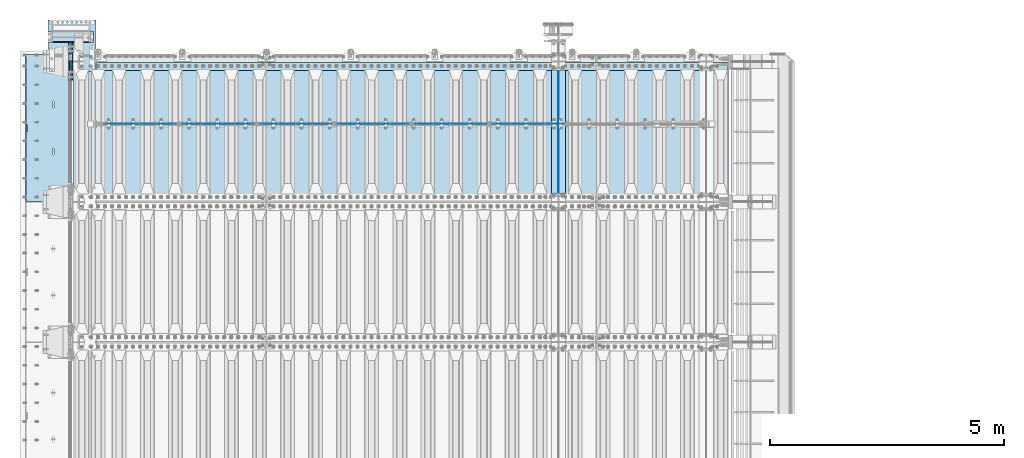
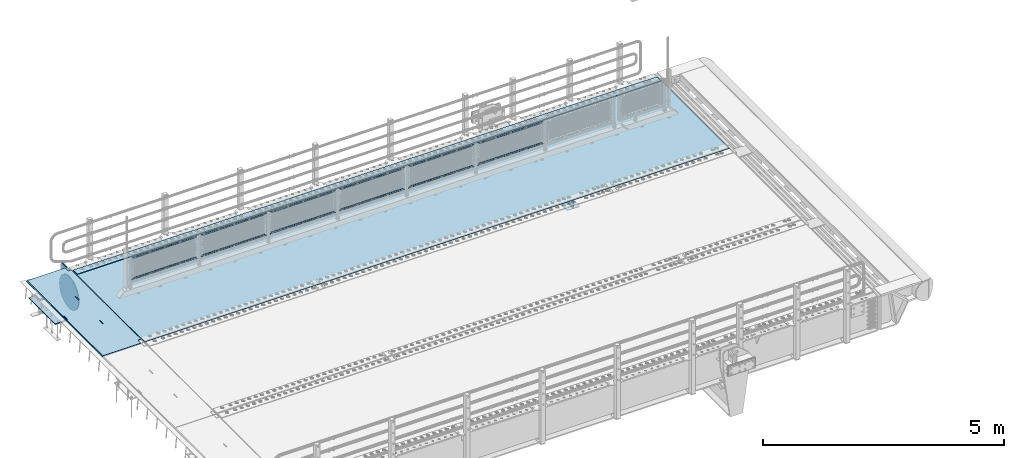
# One storey, part 172 of 219: 21 plates.
"""IFC2X3 building model written with IfcOpenShell, lengths in millimetres."""

from ifc_helpers import new_model, si_unit, frame, origin_with_axes, place, context, subcontext, project, spatial, faceted_brep, material, type_object, element, save


model = new_model("IFC2X3")

# Units and contexts
model_context = context("Model", 3, precision=1e-05, world=origin_with_axes())
body_context = subcontext(model_context, "Body", "Model", "MODEL_VIEW")
ifc_project = project(units=[si_unit("LENGTHUNIT", "METRE", prefix="MILLI"), si_unit("AREAUNIT", "SQUARE_METRE"), si_unit("VOLUMEUNIT", "CUBIC_METRE"), si_unit("MASSUNIT", "GRAM", prefix="KILO"), si_unit("TIMEUNIT", "SECOND"), si_unit("PLANEANGLEUNIT", "RADIAN"), si_unit("SOLIDANGLEUNIT", "STERADIAN"), si_unit("THERMODYNAMICTEMPERATUREUNIT", "DEGREE_CELSIUS"), si_unit("LUMINOUSINTENSITYUNIT", "LUMEN")], contexts=[model_context])

# Site, building, storey
site_placement = place(None, origin_with_axes())
site = spatial("IfcSite", under=ifc_project, at=site_placement, CompositionType="ELEMENT")
building_placement = place(site_placement, origin_with_axes())
building = spatial("IfcBuilding", under=site, at=building_placement, Name="Standard", CompositionType="ELEMENT")
storey_placement = place(building_placement, origin_with_axes())
storey = spatial("IfcBuildingStorey", under=building, at=storey_placement, Name="Undefined", CompositionType="ELEMENT", Elevation=0.0)

# Plates
ifc_material_1 = material(Name="STEEL/S355N")
plate_type_1 = type_object("IfcPlateType", PredefinedType="NOTDEFINED")
plate_1_placement = place(storey_placement, frame((-5.0037545708802, 33149.9999261293, -0.984391683369127), z_axis=(0.0, -0.999999999987744, -4.95099999993769e-06), x_axis=(-0.999999999879068, -1.00000022172504e-09, -1.55519999981193e-05)))
element("IfcPlate", 1, at=plate_1_placement, inside=storey, type_object=plate_type_1, material=ifc_material_1, context=body_context, shape_type="Brep", body=[
    faceted_brep([(14.9998601691701, 15.0, 125.000024820867), (-0.000294611402126499, -0.000806902977099622, 124.999936248674), (-0.0019194158154896, 0.000806844435372156, 3020.00000492308), (14.9966216875132, 15.0, 3020.00007976656), (999.996459960937, 4.99999999999999, 3.63797880709171e-12), (984.996459960937, 15.0, 3.63797880709171e-12), (984.996459718778, 15.0, 3145.0), (999.996459718778, 4.99999999999999, 3145.0), (984.996459961366, -15.0, 0.0), (999.996459960937, -5.0, 3.63797880709171e-12), (999.996459718778, -5.0, 3145.0), (984.996459719206, -15.0, 3145.0), (74.999782061445, -15.0, 0.0), (74.9996421865538, -15.0000000127077, 124.999930084141), (75.0001087165527, 15.0, 125.00007975414), (75.0002485914438, 15.0, 0.0), (-0.000449375328763324, -14.9999999951864, 124.999861417786), (395.486056604107, -15.0000000067239, 2004.409830054), (395.486056604107, 15.0, 2004.409830054), (394.996621766821, 15.0, 2007.49999999776), (394.996621766821, -15.0000000067363, 2007.49999999776), (396.906451823524, -15.0000000066914, 2001.62214747483), (396.906451823524, 15.0, 2001.62214747483), (399.11876924452, -15.0000000066418, 1999.409830054), (399.11876924452, 15.0, 1999.409830054), (401.906451823804, -15.0000000065801, 1997.98943483481), (401.906451823804, 15.0, 1997.9894348348), (404.996621767592, -15.0000000065123, 1997.49999999776), (404.996621767592, 15.0, 1997.49999999775), (408.086791711187, -15.0000000064451, 1997.9894348348), (408.086791711187, 15.0, 1997.9894348348), (410.874474290252, -15.0000000063849, 1999.409830054), (410.874474290252, 15.0, 1999.409830054), (413.086791710906, -15.0000000063378, 2001.62214747483), (413.086791710906, 15.0, 2001.62214747482), (414.507186929894, -15.0000000063082, 2004.409830054), (414.507186929894, 15.0, 2004.409830054), (414.996621766706, -15.0000000062992, 2007.49999999775), (414.996621766706, 15.0, 2007.49999999774), (414.996621756792, -15.0000000063698, 2137.49999999775), (414.996621756792, 15.0, 2137.49999999774), (414.507186919508, -15.0000000063821, 2140.5901699415), (414.507186919508, 15.0, 2140.5901699415), (413.086791700092, -15.0000000064147, 2143.37785252068), (413.086791700092, 15.0, 2143.37785252067), (410.874474279096, -15.0000000064642, 2145.5901699415), (410.874474279096, 15.0, 2145.5901699415), (408.08679169981, -15.0000000065259, 2147.01056516071), (408.08679169981, 15.0, 2147.01056516071), (404.996621756022, -15.0000000065937, 2147.49999999775), (404.996621756022, 15.0, 2147.49999999775), (401.906451812318, -15.000000006661, 2147.01056516071), (401.906451812318, 15.0, 2147.0105651607), (399.118769233252, -15.0000000067211, 2145.5901699415), (399.118769233252, 15.0, 2145.5901699415), (396.906451812598, -15.0000000067683, 2143.37785252068), (396.906451812598, 15.0, 2143.37785252068), (395.486056593611, -15.0000000067978, 2140.5901699415), (395.486056593611, 15.0, 2140.5901699415), (394.996621756801, -15.0000000068068, 2137.49999999776), (394.996621756801, 15.0, 2137.49999999776), (960.486056642603, -14.9999999941054, 1504.40983005424), (960.486056642603, 15.0, 1504.40983005424), (959.996621805317, 15.0, 1507.49999999799), (959.996621805317, -14.9999999941178, 1507.49999999799), (961.90645186202, -14.9999999940729, 1501.62214747507), (961.906451862021, 15.0, 1501.62214747506), (964.118769283016, -14.9999999940233, 1499.40983005424), (964.118769283016, 15.0, 1499.40983005424), (966.9064518623, -14.9999999939616, 1497.98943483504), (966.906451862301, 15.0, 1497.98943483504), (969.996621806087, -14.9999999938938, 1497.49999999799), (969.996621806088, 15.0, 1497.49999999799), (973.086791749683, -14.9999999938266, 1497.98943483504), (973.086791749683, 15.0, 1497.98943483504), (975.874474328748, -14.9999999937664, 1499.40983005424), (975.874474328748, 15.0, 1499.40983005424), (978.086791749402, -14.9999999937193, 1501.62214747506), (978.086791749402, 15.0, 1501.62214747506), (979.50718696839, -14.9999999936897, 1504.40983005424), (979.50718696839, 15.0, 1504.40983005424), (979.996621805202, -14.9999999936807, 1507.49999999798), (979.996621805202, 15.0, 1507.49999999798), (979.996621795288, -14.9999999937513, 1637.49999999798), (979.996621795288, 15.0, 1637.49999999798), (979.507186958004, -14.9999999937636, 1640.59016994173), (979.507186958004, 15.0, 1640.59016994173), (978.086791738588, -14.9999999937962, 1643.37785252092), (978.086791738588, 15.0, 1643.37785252092), (975.874474317592, -14.9999999938457, 1645.59016994174), (975.874474317592, 15.0, 1645.59016994174), (973.086791738306, -14.9999999939074, 1647.01056516094), (973.086791738306, 15.0, 1647.01056516094), (969.996621794518, -14.9999999939752, 1647.499999998), (969.996621794518, 15.0, 1647.49999999799), (966.906451850814, -14.9999999940425, 1647.01056516094), (966.906451850814, 15.0, 1647.01056516094), (964.118769271748, -14.9999999941026, 1645.59016994174), (964.118769271748, 15.0, 1645.59016994174), (961.906451851094, -14.9999999941498, 1643.37785252092), (961.906451851094, 15.0, 1643.37785252092), (960.486056632107, -14.9999999941793, 1640.59016994174), (960.486056632107, 15.0, 1640.59016994174), (959.996621795297, -14.9999999941883, 1637.49999999799), (959.996621795297, 15.0, 1637.49999999799), (74.9967306508983, 15.0, 3145.0), (74.9962640908995, -15.0, 3145.0), (74.9968705257886, 15.0, 3020.00007982416), (74.9964039657899, -15.0, 3019.99993015416), (-0.000460362174934836, -15.00000004538, 3019.99993008595), (395.486056670595, -15.0000000062551, 1140.59016994198), (396.906451889582, -15.0000000062256, 1143.37785252116), (399.118769310236, -15.0000000061784, 1145.59016994198), (401.906451889302, -15.0000000061183, 1147.01056516119), (404.996621833006, -15.000000006051, 1147.49999999823), (408.086791776794, -15.0000000059832, 1147.01056516119), (410.87447435608, -15.0000000059215, 1145.59016994198), (413.086791777076, -15.000000005872, 1143.37785252116), (414.507186996492, -15.0000000058395, 1140.59016994198), (414.996621833776, -15.0000000058271, 1137.49999999823), (414.99662184369, -15.0000000057565, 1007.49999999823), (414.507187006878, -15.0000000057655, 1004.40983005448), (413.08679178789, -15.0000000057951, 1001.62214747531), (410.874474367236, -15.0000000058422, 999.409830054483), (408.086791788171, -15.0000000059024, 997.989434835283), (404.996621844575, -15.0000000059696, 997.499999998232), (401.906451900788, -15.0000000060374, 997.989434835286), (399.118769321504, -15.0000000060991, 999.409830054483), (396.906451900508, -15.0000000061487, 1001.62214747531), (395.486056681091, -15.0000000061812, 1004.40983005449), (394.996621843805, -15.0000000061936, 1007.49999999824), (394.996621833785, -15.0000000062641, 1137.49999999824), (396.906451900508, 15.0, 1001.62214747531), (395.486056681091, 15.0, 1004.40983005448), (399.118769321504, 15.0, 999.409830054483), (401.906451900788, 15.0, 997.989434835283), (404.996621844575, 15.0, 997.499999998228), (408.086791788171, 15.0, 997.989434835283), (410.874474367236, 15.0, 999.409830054483), (413.08679178789, 15.0, 1001.6221474753), (414.507187006878, 15.0, 1004.40983005448), (414.99662184369, 15.0, 1007.49999999822), (414.996621833776, 15.0, 1137.49999999822), (414.507186996492, 15.0, 1140.59016994198), (413.086791777076, 15.0, 1143.37785252115), (410.87447435608, 15.0, 1145.59016994198), (408.086791776794, 15.0, 1147.01056516119), (404.996621833006, 15.0, 1147.49999999823), (401.906451889302, 15.0, 1147.01056516118), (399.118769310236, 15.0, 1145.59016994198), (396.906451889582, 15.0, 1143.37785252116), (395.486056670595, 15.0, 1140.59016994198), (394.996621833785, 15.0, 1137.49999999824), (394.996621843805, 15.0, 1007.49999999824)], [[[0, 1, 2, 3]], [[4, 5, 6, 7]], [[8, 9, 10, 11]], [[12, 13, 14, 15]], [[14, 13, 16, 1, 0]], [[17, 18, 19, 20]], [[21, 22, 18, 17]], [[23, 24, 22, 21]], [[25, 26, 24, 23]], [[27, 28, 26, 25]], [[29, 30, 28, 27]], [[31, 32, 30, 29]], [[33, 34, 32, 31]], [[35, 36, 34, 33]], [[37, 38, 36, 35]], [[39, 40, 38, 37]], [[41, 42, 40, 39]], [[43, 44, 42, 41]], [[45, 46, 44, 43]], [[47, 48, 46, 45]], [[49, 50, 48, 47]], [[51, 52, 50, 49]], [[53, 54, 52, 51]], [[55, 56, 54, 53]], [[57, 58, 56, 55]], [[59, 60, 58, 57]], [[20, 19, 60, 59]], [[61, 62, 63, 64]], [[65, 66, 62, 61]], [[67, 68, 66, 65]], [[69, 70, 68, 67]], [[71, 72, 70, 69]], [[73, 74, 72, 71]], [[75, 76, 74, 73]], [[77, 78, 76, 75]], [[79, 80, 78, 77]], [[81, 82, 80, 79]], [[83, 84, 82, 81]], [[85, 86, 84, 83]], [[87, 88, 86, 85]], [[89, 90, 88, 87]], [[91, 92, 90, 89]], [[93, 94, 92, 91]], [[95, 96, 94, 93]], [[97, 98, 96, 95]], [[99, 100, 98, 97]], [[101, 102, 100, 99]], [[103, 104, 102, 101]], [[64, 63, 104, 103]], [[9, 8, 12, 15, 5, 4]], [[10, 9, 4, 7]], [[105, 106, 11, 10, 7, 6]], [[106, 105, 107, 108]], [[109, 108, 107, 3, 2]], [[106, 108, 109, 16, 13, 12, 8, 11], [101, 99, 97, 95, 93, 91, 89, 87, 85, 83, 81, 79, 77, 75, 73, 71, 69, 67, 65, 61, 64, 103], [57, 55, 53, 51, 49, 47, 45, 43, 41, 39, 37, 35, 33, 31, 29, 27, 25, 23, 21, 17, 20, 59], [110, 111, 112, 113, 114, 115, 116, 117, 118, 119, 120, 121, 122, 123, 124, 125, 126, 127, 128, 129, 130, 131]], [[128, 132, 133, 129]], [[127, 134, 132, 128]], [[126, 135, 134, 127]], [[125, 136, 135, 126]], [[124, 137, 136, 125]], [[123, 138, 137, 124]], [[122, 139, 138, 123]], [[121, 140, 139, 122]], [[120, 141, 140, 121]], [[119, 142, 141, 120]], [[118, 143, 142, 119]], [[117, 144, 143, 118]], [[116, 145, 144, 117]], [[115, 146, 145, 116]], [[114, 147, 146, 115]], [[113, 148, 147, 114]], [[112, 149, 148, 113]], [[111, 150, 149, 112]], [[110, 151, 150, 111]], [[131, 152, 151, 110]], [[130, 153, 152, 131]], [[129, 133, 153, 130]], [[107, 105, 6, 5, 15, 14, 0, 3], [132, 134, 135, 136, 137, 138, 139, 140, 141, 142, 143, 144, 145, 146, 147, 148, 149, 150, 151, 152, 153, 133], [22, 24, 26, 28, 30, 32, 34, 36, 38, 40, 42, 44, 46, 48, 50, 52, 54, 56, 58, 60, 19, 18], [66, 68, 70, 72, 74, 76, 78, 80, 82, 84, 86, 88, 90, 92, 94, 96, 98, 100, 102, 104, 63, 62]], [[16, 109, 2, 1]]]),
])
plate_type_2 = type_object("IfcPlateType", PredefinedType="NOTDEFINED")
plate_2_placement = place(storey_placement, frame((10390.0, 32825.0, 0.0), z_axis=(0.0, 0.0, -1.0), x_axis=(0.0, -1.0, 0.0)))
element("IfcPlate", 2, at=plate_2_placement, inside=storey, type_object=plate_type_2, material=ifc_material_1, context=body_context, shape_type="Brep", body=[
    faceted_brep([(0.0, -5.0, 0.0), (0.0, -5.0, 336.0), (0.0, 5.0, 336.0), (0.0, 5.0, 0.0), (2650.0, -5.0, 336.0), (2650.0, 5.0, 336.0), (2650.0, -5.0, 0.0), (2650.0, 5.0, 0.0)], [[[0, 1, 2, 3]], [[1, 4, 5, 2]], [[4, 6, 7, 5]], [[6, 0, 3, 7]], [[5, 7, 3, 2]], [[6, 4, 1, 0]]]),
])
plate_type_3 = type_object("IfcPlateType", PredefinedType="NOTDEFINED")
plate_3_placement = place(storey_placement, frame((10240.0, 30175.0, -343.0), z_axis=(0.0, 1.0, 0.0), x_axis=(1.0, 0.0, 0.0)))
element("IfcPlate", 3, at=plate_3_placement, inside=storey, type_object=plate_type_3, material=ifc_material_1, context=body_context, shape_type="Brep", body=[
    faceted_brep([(0.0, -7.0, 0.0), (0.0, -7.0, 2650.0), (0.0, 7.0, 2650.0), (0.0, 7.0, 0.0), (300.0, -7.0, 2650.0), (300.0, 7.0, 2650.0), (300.0, -7.0, 0.0), (300.0, 7.0, 0.0)], [[[0, 1, 2, 3]], [[1, 4, 5, 2]], [[4, 6, 7, 5]], [[6, 0, 3, 7]], [[5, 7, 3, 2]], [[6, 4, 1, 0]]]),
])
ifc_material_2 = material(Name="Misc_Undefined")
plate_type_4 = type_object("IfcPlateType", PredefinedType="NOTDEFINED")
plate_4_placement = place(storey_placement, frame((8964.50501173036, 31670.5, 351.520303374641), z_axis=(0.0, 0.0, 1.0), x_axis=(1.0, 0.0, 0.0)))
element("IfcPlate", 4, at=plate_4_placement, inside=storey, type_object=plate_type_4, material=ifc_material_2, context=body_context, shape_type="Brep", body=[
    faceted_brep([(0.0, -1.5, -5.6843418860808e-14), (35.0002975463885, -1.5, 34.9996948242187), (35.0002975463885, 1.5, 34.9996948242187), (0.0, 1.5, -5.6843418860808e-14), (1515.99035644531, -1.5, 34.9999923706054), (1515.99035644531, 1.5, 34.9999923706054), (1550.98999023438, -1.5, 4.43037606601138e-09), (1550.98999023438, 1.5, 4.43037606601138e-09)], [[[0, 1, 2, 3]], [[1, 4, 5, 2]], [[4, 6, 7, 5]], [[6, 0, 3, 7]], [[5, 7, 3, 2]], [[6, 4, 1, 0]]]),
])
plate_5_placement = place(storey_placement, frame((10515.5000001876, 31670.5, 914.520000175701), z_axis=(-0.707103624179499, 0.0, 0.707109938179501), x_axis=(-0.707109938179508, 0.0, -0.707103624179492)))
element("IfcPlate", 5, at=plate_5_placement, inside=storey, type_object=plate_type_4, material=ifc_material_2, context=body_context, shape_type="Brep", body=[
    faceted_brep([(0.0, -1.5, -5.6843418860808e-14), (1096.72753906249, -1.5, 1096.7177734375), (1096.72753906249, 1.5, 1096.7177734375), (0.0, 1.5, -5.6843418860808e-14), (1096.72045898437, -1.5, 1047.21337890625), (1096.72045898437, 1.5, 1047.21337890625), (49.4976959228516, -1.5, -1.0550138540566e-10), (49.4976959228516, 1.5, -1.0550138540566e-10)], [[[0, 1, 2, 3]], [[1, 4, 5, 2]], [[4, 6, 7, 5]], [[6, 0, 3, 7]], [[5, 7, 3, 2]], [[6, 4, 1, 0]]]),
])
plate_6_placement = place(storey_placement, frame((7306.50501173036, 31670.5, 351.520303374641), z_axis=(0.0, 0.0, 1.0), x_axis=(1.0, 0.0, 0.0)))
element("IfcPlate", 6, at=plate_6_placement, inside=storey, type_object=plate_type_4, material=ifc_material_2, context=body_context, shape_type="Brep", body=[
    faceted_brep([(0.0, -1.5, -5.6843418860808e-14), (35.0002975463885, -1.5, 34.9996948242187), (35.0002975463885, 1.5, 34.9996948242187), (0.0, 1.5, -5.6843418860808e-14), (1515.99035644531, -1.5, 34.9999923706054), (1515.99035644531, 1.5, 34.9999923706054), (1550.98999023438, -1.5, 4.43037606601138e-09), (1550.98999023438, 1.5, 4.43037606601138e-09)], [[[0, 1, 2, 3]], [[1, 4, 5, 2]], [[4, 6, 7, 5]], [[6, 0, 3, 7]], [[5, 7, 3, 2]], [[6, 4, 1, 0]]]),
])
plate_7_placement = place(storey_placement, frame((8857.5000001876, 31670.5, 914.520000175701), z_axis=(-0.707103624179499, 0.0, 0.707109938179501), x_axis=(-0.707109938179508, 0.0, -0.707103624179492)))
element("IfcPlate", 7, at=plate_7_placement, inside=storey, type_object=plate_type_4, material=ifc_material_2, context=body_context, shape_type="Brep", body=[
    faceted_brep([(0.0, -1.5, -5.6843418860808e-14), (1096.72753906249, -1.5, 1096.7177734375), (1096.72753906249, 1.5, 1096.7177734375), (0.0, 1.5, -5.6843418860808e-14), (1096.72045898437, -1.5, 1047.21337890625), (1096.72045898437, 1.5, 1047.21337890625), (49.4976959228516, -1.5, -1.0550138540566e-10), (49.4976959228516, 1.5, -1.0550138540566e-10)], [[[0, 1, 2, 3]], [[1, 4, 5, 2]], [[4, 6, 7, 5]], [[6, 0, 3, 7]], [[5, 7, 3, 2]], [[6, 4, 1, 0]]]),
])
plate_8_placement = place(storey_placement, frame((5648.50501173036, 31670.5, 351.520303374641), z_axis=(0.0, 0.0, 1.0), x_axis=(1.0, 0.0, 0.0)))
element("IfcPlate", 8, at=plate_8_placement, inside=storey, type_object=plate_type_4, material=ifc_material_2, context=body_context, shape_type="Brep", body=[
    faceted_brep([(0.0, -1.5, -5.6843418860808e-14), (35.0002975463885, -1.5, 34.9996948242187), (35.0002975463885, 1.5, 34.9996948242187), (0.0, 1.5, -5.6843418860808e-14), (1515.99035644531, -1.5, 34.9999923706054), (1515.99035644531, 1.5, 34.9999923706054), (1550.98999023438, -1.5, 4.43037606601138e-09), (1550.98999023438, 1.5, 4.43037606601138e-09)], [[[0, 1, 2, 3]], [[1, 4, 5, 2]], [[4, 6, 7, 5]], [[6, 0, 3, 7]], [[5, 7, 3, 2]], [[6, 4, 1, 0]]]),
])
plate_9_placement = place(storey_placement, frame((7199.5000001876, 31670.5, 914.520000175701), z_axis=(-0.707103624179499, 0.0, 0.707109938179501), x_axis=(-0.707109938179508, 0.0, -0.707103624179492)))
element("IfcPlate", 9, at=plate_9_placement, inside=storey, type_object=plate_type_4, material=ifc_material_2, context=body_context, shape_type="Brep", body=[
    faceted_brep([(0.0, -1.5, -5.6843418860808e-14), (1096.72753906249, -1.5, 1096.7177734375), (1096.72753906249, 1.5, 1096.7177734375), (0.0, 1.5, -5.6843418860808e-14), (1096.72045898437, -1.5, 1047.21337890625), (1096.72045898437, 1.5, 1047.21337890625), (49.4976959228516, -1.5, -1.0550138540566e-10), (49.4976959228516, 1.5, -1.0550138540566e-10)], [[[0, 1, 2, 3]], [[1, 4, 5, 2]], [[4, 6, 7, 5]], [[6, 0, 3, 7]], [[5, 7, 3, 2]], [[6, 4, 1, 0]]]),
])
plate_10_placement = place(storey_placement, frame((3990.50501173036, 31670.5, 351.520303374641), z_axis=(0.0, 0.0, 1.0), x_axis=(1.0, 0.0, 0.0)))
element("IfcPlate", 10, at=plate_10_placement, inside=storey, type_object=plate_type_4, material=ifc_material_2, context=body_context, shape_type="Brep", body=[
    faceted_brep([(0.0, -1.5, -5.6843418860808e-14), (35.0002975463885, -1.5, 34.9996948242187), (35.0002975463885, 1.5, 34.9996948242187), (0.0, 1.5, -5.6843418860808e-14), (1515.99035644531, -1.5, 34.9999923706054), (1515.99035644531, 1.5, 34.9999923706054), (1550.98999023438, -1.5, 4.43037606601138e-09), (1550.98999023438, 1.5, 4.43037606601138e-09)], [[[0, 1, 2, 3]], [[1, 4, 5, 2]], [[4, 6, 7, 5]], [[6, 0, 3, 7]], [[5, 7, 3, 2]], [[6, 4, 1, 0]]]),
])
plate_11_placement = place(storey_placement, frame((5541.5000001876, 31670.5, 914.520000175701), z_axis=(-0.707103624179499, 0.0, 0.707109938179501), x_axis=(-0.707109938179508, 0.0, -0.707103624179492)))
element("IfcPlate", 11, at=plate_11_placement, inside=storey, type_object=plate_type_4, material=ifc_material_2, context=body_context, shape_type="Brep", body=[
    faceted_brep([(0.0, -1.5, -5.6843418860808e-14), (1096.72753906249, -1.5, 1096.7177734375), (1096.72753906249, 1.5, 1096.7177734375), (0.0, 1.5, -5.6843418860808e-14), (1096.72045898437, -1.5, 1047.21337890625), (1096.72045898437, 1.5, 1047.21337890625), (49.4976959228516, -1.5, -1.0550138540566e-10), (49.4976959228516, 1.5, -1.0550138540566e-10)], [[[0, 1, 2, 3]], [[1, 4, 5, 2]], [[4, 6, 7, 5]], [[6, 0, 3, 7]], [[5, 7, 3, 2]], [[6, 4, 1, 0]]]),
])
plate_12_placement = place(storey_placement, frame((2332.50501173036, 31670.5, 351.520303374641), z_axis=(0.0, 0.0, 1.0), x_axis=(1.0, 0.0, 0.0)))
element("IfcPlate", 12, at=plate_12_placement, inside=storey, type_object=plate_type_4, material=ifc_material_2, context=body_context, shape_type="Brep", body=[
    faceted_brep([(0.0, -1.5, -5.6843418860808e-14), (35.0002975463885, -1.5, 34.9996948242187), (35.0002975463885, 1.5, 34.9996948242187), (0.0, 1.5, -5.6843418860808e-14), (1515.99035644531, -1.5, 34.9999923706054), (1515.99035644531, 1.5, 34.9999923706054), (1550.98999023438, -1.5, 4.43037606601138e-09), (1550.98999023438, 1.5, 4.43037606601138e-09)], [[[0, 1, 2, 3]], [[1, 4, 5, 2]], [[4, 6, 7, 5]], [[6, 0, 3, 7]], [[5, 7, 3, 2]], [[6, 4, 1, 0]]]),
])
plate_13_placement = place(storey_placement, frame((3883.5000001876, 31670.5, 914.520000175701), z_axis=(-0.707103624179499, 0.0, 0.707109938179501), x_axis=(-0.707109938179508, 0.0, -0.707103624179492)))
element("IfcPlate", 13, at=plate_13_placement, inside=storey, type_object=plate_type_4, material=ifc_material_2, context=body_context, shape_type="Brep", body=[
    faceted_brep([(0.0, -1.5, -5.6843418860808e-14), (1096.72753906249, -1.5, 1096.7177734375), (1096.72753906249, 1.5, 1096.7177734375), (0.0, 1.5, -5.6843418860808e-14), (1096.72045898437, -1.5, 1047.21337890625), (1096.72045898437, 1.5, 1047.21337890625), (49.4976959228516, -1.5, -1.0550138540566e-10), (49.4976959228516, 1.5, -1.0550138540566e-10)], [[[0, 1, 2, 3]], [[1, 4, 5, 2]], [[4, 6, 7, 5]], [[6, 0, 3, 7]], [[5, 7, 3, 2]], [[6, 4, 1, 0]]]),
])
plate_14_placement = place(storey_placement, frame((674.505011730362, 31670.5, 351.520303374641), z_axis=(0.0, 0.0, 1.0), x_axis=(1.0, 0.0, 0.0)))
element("IfcPlate", 14, at=plate_14_placement, inside=storey, type_object=plate_type_4, material=ifc_material_2, context=body_context, shape_type="Brep", body=[
    faceted_brep([(0.0, -1.5, -5.6843418860808e-14), (35.0002975463885, -1.5, 34.9996948242187), (35.0002975463885, 1.5, 34.9996948242187), (0.0, 1.5, -5.6843418860808e-14), (1515.99035644531, -1.5, 34.9999923706054), (1515.99035644531, 1.5, 34.9999923706054), (1550.98999023438, -1.5, 4.43037606601138e-09), (1550.98999023438, 1.5, 4.43037606601138e-09)], [[[0, 1, 2, 3]], [[1, 4, 5, 2]], [[4, 6, 7, 5]], [[6, 0, 3, 7]], [[5, 7, 3, 2]], [[6, 4, 1, 0]]]),
])
plate_15_placement = place(storey_placement, frame((2225.5000001876, 31670.5, 914.520000175701), z_axis=(-0.707103624179499, 0.0, 0.707109938179501), x_axis=(-0.707109938179508, 0.0, -0.707103624179492)))
element("IfcPlate", 15, at=plate_15_placement, inside=storey, type_object=plate_type_4, material=ifc_material_2, context=body_context, shape_type="Brep", body=[
    faceted_brep([(0.0, -1.5, -5.6843418860808e-14), (1096.72753906249, -1.5, 1096.7177734375), (1096.72753906249, 1.5, 1096.7177734375), (0.0, 1.5, -5.6843418860808e-14), (1096.72045898437, -1.5, 1047.21337890625), (1096.72045898437, 1.5, 1047.21337890625), (49.4976959228516, -1.5, -1.0550138540566e-10), (49.4976959228516, 1.5, -1.0550138540566e-10)], [[[0, 1, 2, 3]], [[1, 4, 5, 2]], [[4, 6, 7, 5]], [[6, 0, 3, 7]], [[5, 7, 3, 2]], [[6, 4, 1, 0]]]),
])
ifc_material_3 = material()
plate_type_5 = type_object("IfcPlateType", PredefinedType="NOTDEFINED")
plate_16_placement = place(storey_placement, frame((455.000000000015, 33645.0, -803.000000000004), z_axis=(0.0, -1.0, 0.0), x_axis=(-1.0, 0.0, 0.0)))
element("IfcPlate", 16, at=plate_16_placement, inside=storey, type_object=plate_type_5, material=ifc_material_3, context=body_context, shape_type="Brep", body=[
    faceted_brep([(0.0, 0.0, 235.0), (0.0, -15.0, 220.0), (979.0, -15.0, 220.0), (979.0, 0.0, 235.0), (0.0, 15.0, 235.0), (0.0, 15.0, 0.0), (0.0, -15.0, 0.0), (979.0, 15.0, 235.0), (979.0, -15.0, 0.0), (979.0, 15.0, 0.0)], [[[0, 1, 2, 3]], [[4, 5, 6, 1, 0]], [[7, 4, 0, 3]], [[8, 9, 7, 3, 2]], [[8, 6, 5, 9]], [[7, 9, 5, 4]], [[6, 8, 2, 1]]]),
])
plate_type_6 = type_object("IfcPlateType", PredefinedType="NOTDEFINED")
plate_17_placement = place(storey_placement, frame((-523.999999999987, 33890.0, -1043.0), z_axis=(1.0, 0.0, 0.0), x_axis=(0.0, -1.0, 0.0)))
element("IfcPlate", 17, at=plate_17_placement, inside=storey, type_object=plate_type_6, material=ifc_material_3, context=body_context, shape_type="Brep", body=[
    faceted_brep([(0.0, -15.0, 0.0), (3.03448287013453e-05, -15.0, 1025.0), (3.03448287013453e-05, 15.0, 1025.0), (0.0, 15.0, 0.0), (1100.0, -15.0, 1025.0), (1100.0, 15.0, 1025.0), (1100.0, -15.0, -1.9554136088118e-11), (1100.0, 15.0, -1.9554136088118e-11)], [[[0, 1, 2, 3]], [[1, 4, 5, 2]], [[4, 6, 7, 5]], [[6, 0, 3, 7]], [[5, 7, 3, 2]], [[6, 4, 1, 0]]]),
])
ifc_material_4 = material(Name="STEEL/S235JR")
plate_type_7 = type_object("IfcPlateType", PredefinedType="NOTDEFINED")
plate_18_placement = place(storey_placement, frame((14017.0, 32815.0, 20.0), z_axis=(-1.0, 0.0, 0.0), x_axis=(0.0, 1.0, 0.0)))
element("IfcPlate", 18, at=plate_18_placement, inside=storey, type_object=plate_type_7, material=ifc_material_4, context=body_context, shape_type="Brep", body=[
    faceted_brep([(0.0, -6.0, 0.0), (0.0, -6.0, 13997.0), (0.0, 6.0, 13997.0), (0.0, 6.0, 0.0), (170.0, -6.0, 13997.0), (170.0, 6.0, 13997.0), (170.0, -6.0, 0.0), (170.0, 6.0, 0.0)], [[[0, 1, 2, 3]], [[1, 4, 5, 2]], [[4, 6, 7, 5]], [[6, 0, 3, 7]], [[5, 7, 3, 2]], [[6, 4, 1, 0]]]),
])
plate_type_8 = type_object("IfcPlateType", PredefinedType="NOTDEFINED")
plate_19_placement = place(storey_placement, frame((10.0, 32995.0, 7.0), z_axis=(1.0, 0.0, 0.0), x_axis=(0.0, -1.0, 0.0)))
element("IfcPlate", 19, at=plate_19_placement, inside=storey, type_object=plate_type_8, material=ifc_material_1, context=body_context, shape_type="Brep", body=[
    faceted_brep([(0.0, -7.0, 0.0), (-2.96859070658684e-09, -7.0, 14017.0), (-2.96859070658684e-09, 7.0, 14017.0), (0.0, 7.0, 0.0), (2990.0, -7.0, 14017.0), (2990.0, 7.0, 14017.0), (2990.0, -7.0, 0.0), (2990.0, 7.0, 0.0)], [[[0, 1, 2, 3]], [[1, 4, 5, 2]], [[4, 6, 7, 5]], [[6, 0, 3, 7]], [[5, 7, 3, 2]], [[6, 4, 1, 0]]]),
])
plate_type_9 = type_object("IfcPlateType", PredefinedType="NOTDEFINED")
plate_20_placement = place(storey_placement, frame((-62.5000000000001, 33400.0, -114.999999999998), z_axis=(0.0, 0.0, -1.0), x_axis=(0.0, -1.0, 0.0)))
element("IfcPlate", 20, at=plate_20_placement, inside=storey, type_object=plate_type_9, material=ifc_material_1, context=body_context, shape_type="Brep", body=[
    faceted_brep([(0.0, -12.5, 400.0), (2.91645036198315, -12.5, 448.214672101512), (2.91645036198315, 12.5, 448.214672101512), (0.0, 12.5, 400.0), (11.6232730309421, -12.5, 495.72626571426), (11.6232730309421, 12.5, 495.72626571426), (25.9935029273329, -12.5, 541.8419548161), (25.9935029273329, 12.5, 541.8419548161), (45.8175897403271, -12.5, 585.889268816449), (45.8175897403271, 12.5, 585.889268816449), (70.8064536442325, -12.5, 627.225898691271), (70.8064536442325, 12.5, 627.225898691271), (100.595700733313, -12.5, 665.249063294999), (100.595700733313, 12.5, 665.249063294999), (134.750936705474, -12.5, 699.404299267018), (134.750936705474, 12.5, 699.404299267018), (172.774101309333, -12.5, 729.193546355957), (172.774101309333, 12.5, 729.193546355957), (214.110731184279, -12.5, 754.182410259709), (214.110731184279, 12.5, 754.182410259709), (258.15804518474, -12.5, 774.006497072558), (258.15804518474, 12.5, 774.006497072558), (304.273734286682, -12.5, 788.376726968803), (304.273734286682, 12.5, 788.376726968803), (351.785327899517, -12.5, 797.08354963762), (351.785327899517, 12.5, 797.08354963762), (400.0, -12.5, 800.0), (400.0, 12.5, 800.0), (448.21467210335, -12.5, 797.083549637642), (448.21467210335, 12.5, 797.083549637642), (495.726265715995, -12.5, 788.37672696916), (495.726265715995, 12.5, 788.37672696916), (541.841954817748, -12.5, 774.006497073235), (541.841954817748, 12.5, 774.006497073235), (585.889268818006, -12.5, 754.182410260695), (585.889268818006, 12.5, 754.182410260695), (627.225898692734, -12.5, 729.193546357212), (627.225898692734, 12.5, 729.193546357212), (665.249063296356, -12.5, 699.404299268539), (665.249063296356, 12.5, 699.404299268539), (699.404299268259, -12.5, 665.24906329676), (699.404299268259, 12.5, 665.24906329676), (729.193546357063, -12.5, 627.22589869325), (729.193546357063, 12.5, 627.22589869325), (754.18241026067, -12.5, 585.889268818639), (754.18241026067, 12.5, 585.889268818639), (774.006497073347, -12.5, 541.841954818479), (774.006497073347, 12.5, 541.841954818479), (788.376726969396, -12.5, 495.726265716821), (788.376726969396, 12.5, 495.726265716821), (797.083549638002, -12.5, 448.214672104252), (797.083549638002, 12.5, 448.214672104252), (800.0, -12.5, 400.0), (800.0, 12.5, 400.0), (797.083549639287, -12.5, 351.785327898364), (797.083549639287, 12.5, 351.785327898364), (788.376726970528, -12.5, 304.273734285453), (788.376726970528, 12.5, 304.273734285453), (774.006497074311, -12.5, 258.158045183416), (774.006497074311, 12.5, 258.158045183416), (754.182410261463, -12.5, 214.110731182853), (754.182410261463, 12.5, 214.110731182853), (729.193546357659, -12.5, 172.774101307812), (729.193546357659, 12.5, 172.774101307812), (699.404299268663, -12.5, 134.750936703855), (699.404299268663, 12.5, 134.750936703855), (665.24906329656, -12.5, 100.595700731628), (665.24906329656, 12.5, 100.595700731628), (627.225898692719, -12.5, 70.8064536425045), (627.225898692719, 12.5, 70.8064536425045), (585.889268817788, -12.5, 45.8175897385809), (585.889268817788, 12.5, 45.8175897385809), (541.841954817326, -12.5, 25.9935029256012), (541.841954817326, 12.5, 25.9935029256012), (495.726265715377, -12.5, 11.6232730292504), (495.726265715377, 12.5, 11.6232730292504), (448.214672102542, -12.5, 2.91645036037517), (448.214672102542, 12.5, 2.91645036037517), (400.0, -12.5, -5.6843418860808e-14), (400.0, 12.5, -5.6843418860808e-14), (351.785327896665, -12.5, 2.91645036236514), (351.785327896665, 12.5, 2.91645036236514), (304.273734284012, -12.5, 11.6232730308511), (304.273734284012, 12.5, 11.6232730308511), (258.158045182267, -12.5, 25.9935029267763), (258.158045182267, 12.5, 25.9935029267763), (214.110731182009, -12.5, 45.8175897393157), (214.110731182009, 12.5, 45.8175897393157), (172.774101307281, -12.5, 70.8064536427992), (172.774101307281, 12.5, 70.8064536427992), (134.750936703655, -12.5, 100.595700731472), (134.750936703655, 12.5, 100.595700731472), (100.595700731748, -12.5, 134.750936703247), (100.595700731748, 12.5, 134.750936703247), (70.8064536429447, -12.5, 172.774101306761), (70.8064536429447, 12.5, 172.774101306761), (45.8175897393376, -12.5, 214.110731181379), (45.8175897393376, 12.5, 214.110731181379), (25.9935029266635, -12.5, 258.158045181532), (25.9935029266635, 12.5, 258.158045181532), (11.6232730306074, -12.5, 304.273734283186), (11.6232730306074, 12.5, 304.273734283186), (2.9164503619977, -12.5, 351.785327895759), (2.9164503619977, 12.5, 351.785327895759)], [[[0, 1, 2, 3]], [[1, 4, 5, 2]], [[4, 6, 7, 5]], [[6, 8, 9, 7]], [[8, 10, 11, 9]], [[10, 12, 13, 11]], [[12, 14, 15, 13]], [[14, 16, 17, 15]], [[16, 18, 19, 17]], [[18, 20, 21, 19]], [[20, 22, 23, 21]], [[22, 24, 25, 23]], [[24, 26, 27, 25]], [[26, 28, 29, 27]], [[28, 30, 31, 29]], [[30, 32, 33, 31]], [[32, 34, 35, 33]], [[34, 36, 37, 35]], [[36, 38, 39, 37]], [[38, 40, 41, 39]], [[40, 42, 43, 41]], [[42, 44, 45, 43]], [[44, 46, 47, 45]], [[46, 48, 49, 47]], [[48, 50, 51, 49]], [[50, 52, 53, 51]], [[52, 54, 55, 53]], [[54, 56, 57, 55]], [[56, 58, 59, 57]], [[58, 60, 61, 59]], [[60, 62, 63, 61]], [[62, 64, 65, 63]], [[64, 66, 67, 65]], [[66, 68, 69, 67]], [[68, 70, 71, 69]], [[70, 72, 73, 71]], [[72, 74, 75, 73]], [[74, 76, 77, 75]], [[76, 78, 79, 77]], [[78, 80, 81, 79]], [[80, 82, 83, 81]], [[82, 84, 85, 83]], [[84, 86, 87, 85]], [[86, 88, 89, 87]], [[88, 90, 91, 89]], [[90, 92, 93, 91]], [[92, 94, 95, 93]], [[94, 96, 97, 95]], [[96, 98, 99, 97]], [[98, 100, 101, 99]], [[100, 102, 103, 101]], [[102, 0, 3, 103]], [[5, 7, 9, 11, 13, 15, 17, 19, 21, 23, 25, 27, 29, 31, 33, 35, 37, 39, 41, 43, 45, 47, 49, 51, 53, 55, 57, 59, 61, 63, 65, 67, 69, 71, 73, 75, 77, 79, 81, 83, 85, 87, 89, 91, 93, 95, 97, 99, 101, 103, 3, 2]], [[102, 100, 98, 96, 94, 92, 90, 88, 86, 84, 82, 80, 78, 76, 74, 72, 70, 68, 66, 64, 62, 60, 58, 56, 54, 52, 50, 48, 46, 44, 42, 40, 38, 36, 34, 32, 30, 28, 26, 24, 22, 20, 18, 16, 14, 12, 10, 8, 6, 4, 1, 0]]]),
])
plate_type_10 = type_object("IfcPlateType", PredefinedType="NOTDEFINED")
plate_21_placement = place(storey_placement, frame((-5.0, 32600.0, -20.0), z_axis=(0.0, 1.0, 0.0), x_axis=(0.0, 0.0, -1.0)))
element("IfcPlate", 21, at=plate_21_placement, inside=storey, type_object=plate_type_10, material=ifc_material_1, context=body_context, shape_type="Brep", body=[
    faceted_brep([(855.0, -15.0, 572.963114670027), (855.0, 15.0, 572.963114670027), (849.182410260917, 15.0, 585.889268816907), (849.182410260917, -15.0, 585.889268816907), (824.193546357179, 15.0, 627.225898691897), (824.193546357179, -15.0, 627.225898691897), (794.404299268237, 15.0, 665.249063295792), (794.404299268237, -15.0, 665.249063295792), (760.249063296204, 15.0, 699.404299267975), (760.249063296204, -15.0, 699.404299267975), (722.225898692443, 15.0, 729.193546357055), (722.225898692443, -15.0, 729.193546357055), (680.889268817573, 15.0, 754.182410260939), (680.889268817573, -15.0, 754.182410260939), (636.841954817181, 15.0, 774.006497073904), (636.841954817181, -15.0, 774.006497073904), (590.726265715286, 15.0, 788.376726970237), (590.726265715286, -15.0, 788.376726970237), (543.214672102495, 15.0, 797.083549639108), (543.214672102495, -15.0, 797.083549639108), (495.0, -15.0, 800.000000000029), (495.0, 15.0, 800.0), (494.999999999412, -15.0, 0.0), (494.999999999412, 15.0, 0.0), (543.214672105067, 15.0, 2.91645036483533), (543.214672105067, -15.0, 2.91645036483533), (590.726265717545, 15.0, 11.623273033314), (590.726265717545, -15.0, 11.623273033314), (636.841954819123, 15.0, 25.9935029292174), (636.841954819123, -15.0, 25.9935029292174), (680.889268819221, 15.0, 45.8175897417386), (680.889268819221, -15.0, 45.8175897417386), (722.225898693796, 15.0, 70.8064536451857), (722.225898693796, -15.0, 70.8064536451857), (760.249063297284, 15.0, 100.595700733822), (760.249063297284, -15.0, 100.595700733822), (794.404299269056, 15.0, 134.750936705557), (794.404299269056, -15.0, 134.750936705557), (824.193546357754, 15.0, 172.77410130902), (824.193546357754, -15.0, 172.77410130902), (849.182410261274, 15.0, 214.110731183588), (849.182410261274, -15.0, 214.110731183588), (855.0, -15.0, 227.03688532969), (855.0, 15.0, 227.03688532969), (0.0, -15.0, 0.0), (0.0, 15.0, 0.0), (0.0, 15.0, 800.0), (0.0, -15.0, 800.0)], [[[0, 1, 2, 3]], [[3, 2, 4, 5]], [[5, 4, 6, 7]], [[7, 6, 8, 9]], [[9, 8, 10, 11]], [[11, 10, 12, 13]], [[13, 12, 14, 15]], [[15, 14, 16, 17]], [[17, 16, 18, 19]], [[20, 19, 18, 21]], [[22, 23, 24, 25]], [[25, 24, 26, 27]], [[27, 26, 28, 29]], [[29, 28, 30, 31]], [[31, 30, 32, 33]], [[33, 32, 34, 35]], [[35, 34, 36, 37]], [[37, 36, 38, 39]], [[39, 38, 40, 41]], [[42, 41, 40, 43]], [[42, 43, 1, 0]], [[44, 45, 23, 22]], [[16, 14, 12, 10, 8, 6, 4, 2, 1, 43, 40, 38, 36, 34, 32, 30, 28, 26, 24, 23, 45, 46, 21, 18]], [[44, 47, 46, 45]], [[46, 47, 20, 21]], [[47, 44, 22, 25, 27, 29, 31, 33, 35, 37, 39, 41, 42, 0, 3, 5, 7, 9, 11, 13, 15, 17, 19, 20]]]),
])

save(model, "model.ifc")
